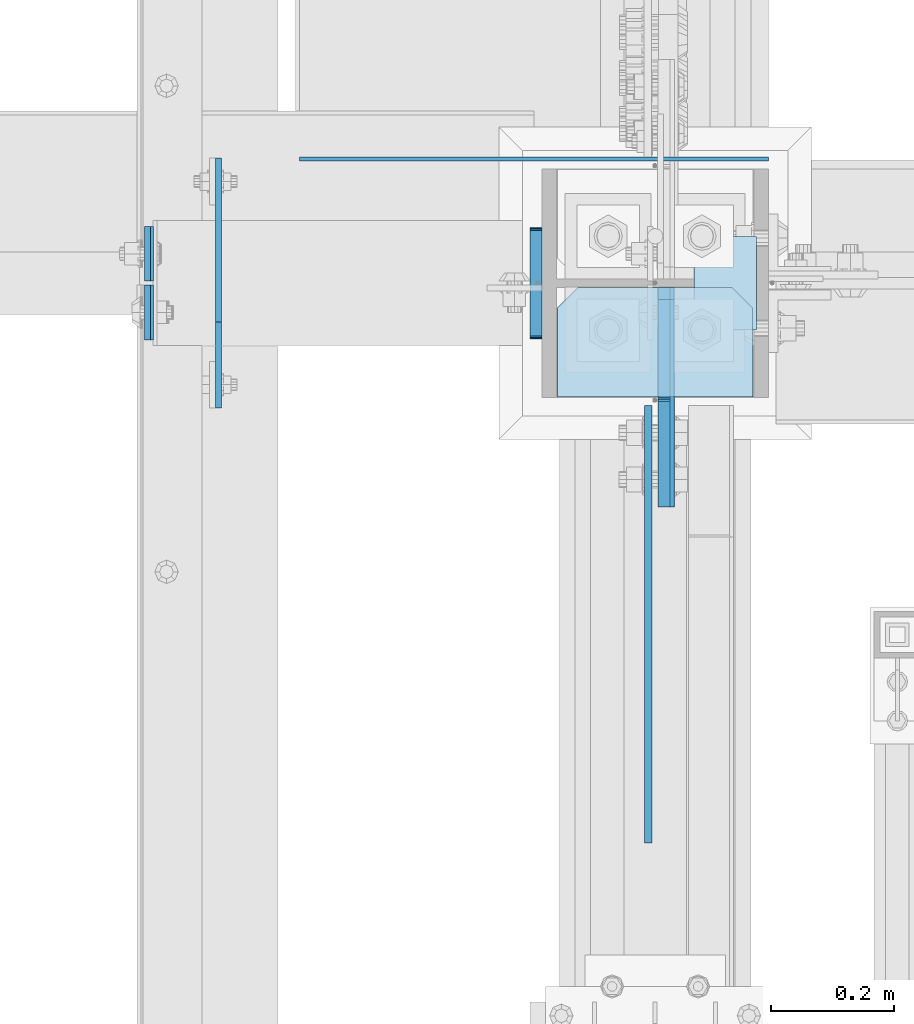
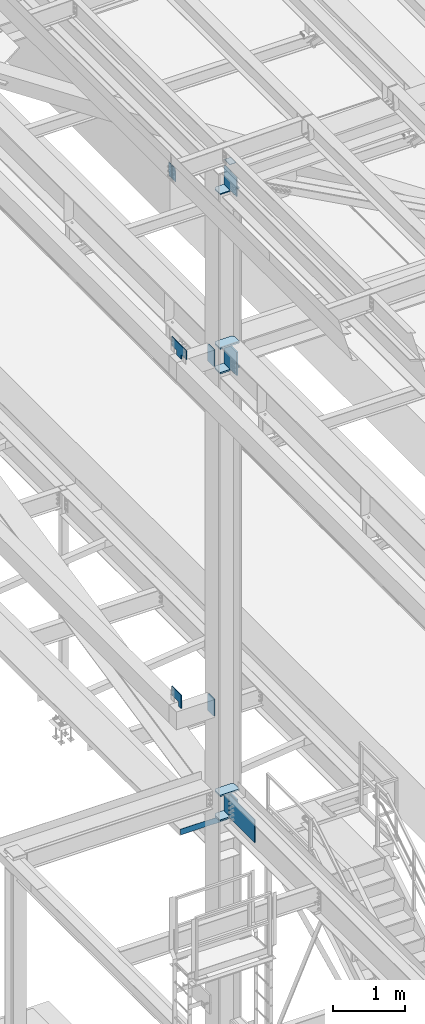
# One storey, part 3208 of 3843: 17 plates, 4 elements without a shape of their own.
"""IFC2X3 building model written with IfcOpenShell, lengths in millimetres."""

from ifc_helpers import new_model, si_unit, frame, origin_with_axes, place, context, subcontext, project, spatial, faceted_brep, material, type_object, element, aggregate, save


model = new_model("IFC2X3")

# Units and contexts
model_context = context("Model", 3, precision=1e-05, world=origin_with_axes())
body_context = subcontext(model_context, "Body", "Model", "MODEL_VIEW")
ifc_project = project(units=[si_unit("LENGTHUNIT", "METRE", prefix="MILLI"), si_unit("AREAUNIT", "SQUARE_METRE"), si_unit("VOLUMEUNIT", "CUBIC_METRE"), si_unit("MASSUNIT", "GRAM", prefix="KILO"), si_unit("TIMEUNIT", "SECOND"), si_unit("PLANEANGLEUNIT", "RADIAN"), si_unit("SOLIDANGLEUNIT", "STERADIAN"), si_unit("THERMODYNAMICTEMPERATUREUNIT", "DEGREE_CELSIUS"), si_unit("LUMINOUSINTENSITYUNIT", "LUMEN")], contexts=[model_context])

# Site, building, storey
site_placement = place(None, origin_with_axes())
site = spatial("IfcSite", under=ifc_project, at=site_placement, CompositionType="ELEMENT")
building_placement = place(site_placement, origin_with_axes())
building = spatial("IfcBuilding", under=site, at=building_placement, Name="Undefined", CompositionType="ELEMENT")
storey_placement = place(building_placement, origin_with_axes())
storey = spatial("IfcBuildingStorey", under=building, at=storey_placement, Name="Undefined", CompositionType="ELEMENT", Elevation=0.0)

# Assembly, plates
assembly_1_placement = place(storey_placement, origin_with_axes())
assembly_1 = element("IfcElementAssembly", 1, at=assembly_1_placement, inside=storey, Name="COLUMN", AssemblyPlace="NOTDEFINED", PredefinedType="RIGID_FRAME")
ifc_material = material(Name="STEEL/A572-50")
plate_type_1 = type_object("IfcPlateType", PredefinedType="NOTDEFINED")
plate_1_placement = place(assembly_1_placement, frame((36417.25, 33660.55625, 42005.249987793), z_axis=(1.0, 0.0, 0.0), x_axis=(0.0, 1.0, 0.0)))
plate_1 = element("IfcPlate", 2, at=plate_1_placement, type_object=plate_type_1, material=ifc_material, Name="PLATE", context=body_context, shape_type="Brep", body=[
    faceted_brep([(0.0, -12.6999999999971, 0.0), (0.0, -12.7000000020344, 317.500000001608), (0.0, 12.6999999977998, 317.500000001586), (0.0, 12.6999999999971, 0.0), (144.462501525879, -12.6999999999971, 317.5), (144.462501525879, 12.6999999999971, 317.5), (177.800003051758, -12.6999999999971, 284.162498474121), (177.800003051758, 12.6999999999971, 284.162498474121), (177.800003051758, -12.6999999999971, 33.3375015258789), (177.800003051758, 12.6999999999971, 33.3375015258789), (144.462501525879, -12.6999999999971, 0.0), (144.462501525879, 12.6999999999971, 0.0)], [[[0, 1, 2, 3]], [[1, 4, 5, 2]], [[4, 6, 7, 5]], [[6, 8, 9, 7]], [[8, 10, 11, 9]], [[10, 0, 3, 11]], [[5, 7, 9, 11, 3, 2]], [[10, 8, 6, 4, 1, 0]]]),
])
plate_2_placement = place(assembly_1_placement, frame((36417.25, 33660.55625, 42424.35), z_axis=(1.0, 0.0, 0.0), x_axis=(0.0, 1.0, 0.0)))
plate_2 = element("IfcPlate", 3, at=plate_2_placement, type_object=plate_type_1, material=ifc_material, Name="PLATE", context=body_context, shape_type="Brep", body=[
    faceted_brep([(0.0, -12.6999999999971, 0.0), (0.0, -12.7000000020344, 317.500000001608), (0.0, 12.6999999977998, 317.500000001586), (0.0, 12.6999999999971, 0.0), (144.462501525879, -12.6999999999971, 317.5), (144.462501525879, 12.6999999999971, 317.5), (177.800003051758, -12.6999999999971, 284.162498474121), (177.800003051758, 12.6999999999971, 284.162498474121), (177.800003051758, -12.6999999999971, 33.3375015258789), (177.800003051758, 12.6999999999971, 33.3375015258789), (144.462501525879, -12.6999999999971, 0.0), (144.462501525879, 12.6999999999971, 0.0)], [[[0, 1, 2, 3]], [[1, 4, 5, 2]], [[4, 6, 7, 5]], [[6, 8, 9, 7]], [[8, 10, 11, 9]], [[10, 0, 3, 11]], [[5, 7, 9, 11, 3, 2]], [[10, 8, 6, 4, 1, 0]]]),
])
plate_3_placement = place(assembly_1_placement, frame((36417.25, 33660.55625, 34372.55), z_axis=(1.0, 0.0, 0.0), x_axis=(0.0, 1.0, 0.0)))
plate_3 = element("IfcPlate", 4, at=plate_3_placement, type_object=plate_type_1, material=ifc_material, Name="PLATE", context=body_context, shape_type="Brep", body=[
    faceted_brep([(0.0, -12.6999999999971, 0.0), (0.0, -12.7000000020344, 317.500000001608), (0.0, 12.6999999977998, 317.500000001586), (0.0, 12.6999999999971, 0.0), (144.462501525879, -12.6999999999971, 317.5), (144.462501525879, 12.6999999999971, 317.5), (177.800003051758, -12.6999999999971, 284.162498474121), (177.800003051758, 12.6999999999971, 284.162498474121), (177.800003051758, -12.6999999999971, 33.3375015258789), (177.800003051758, 12.6999999999971, 33.3375015258789), (144.462501525879, -12.6999999999971, 0.0), (144.462501525879, 12.6999999999971, 0.0)], [[[0, 1, 2, 3]], [[1, 4, 5, 2]], [[4, 6, 7, 5]], [[6, 8, 9, 7]], [[8, 10, 11, 9]], [[10, 0, 3, 11]], [[5, 7, 9, 11, 3, 2]], [[10, 8, 6, 4, 1, 0]]]),
])
plate_4_placement = place(assembly_1_placement, frame((36417.25, 33660.55625, 34791.65), z_axis=(1.0, 0.0, 0.0), x_axis=(0.0, 1.0, 0.0)))
plate_4 = element("IfcPlate", 5, at=plate_4_placement, type_object=plate_type_1, material=ifc_material, Name="PLATE", context=body_context, shape_type="Brep", body=[
    faceted_brep([(0.0, -12.6999999999971, 0.0), (0.0, -12.7000000020344, 317.500000001608), (0.0, 12.6999999977998, 317.500000001586), (0.0, 12.6999999999971, 0.0), (144.462501525879, -12.6999999999971, 317.5), (144.462501525879, 12.6999999999971, 317.5), (177.800003051758, -12.6999999999971, 284.162498474121), (177.800003051758, 12.6999999999971, 284.162498474121), (177.800003051758, -12.6999999999971, 33.3375015258789), (177.800003051758, 12.6999999999971, 33.3375015258789), (144.462501525879, -12.6999999999971, 0.0), (144.462501525879, 12.6999999999971, 0.0)], [[[0, 1, 2, 3]], [[1, 4, 5, 2]], [[4, 6, 7, 5]], [[6, 8, 9, 7]], [[8, 10, 11, 9]], [[10, 0, 3, 11]], [[5, 7, 9, 11, 3, 2]], [[10, 8, 6, 4, 1, 0]]]),
])
plate_type_2 = type_object("IfcPlateType", PredefinedType="NOTDEFINED")
plate_5_placement = place(assembly_1_placement, frame((36595.0499999046, 33838.35625, 42411.65), z_axis=(0.0, -1.0, 0.0), x_axis=(0.0, 0.0, -1.0)))
plate_5 = element("IfcPlate", 6, at=plate_5_placement, type_object=plate_type_2, material=ifc_material, Name="PLATE", context=body_context, shape_type="Brep", body=[
    faceted_brep([(0.0, -12.6999999999971, 19.0499992370605), (0.0, -12.6999999999971, 356.393737792969), (0.0, 12.6999999999971, 356.393737792969), (0.0, 12.6999999999971, 19.0499992370605), (393.700012207031, -12.6999999999971, 356.393737792969), (393.700012207031, 12.6999999999971, 356.393737792969), (393.700012207031, -12.6999999999971, 19.0499992370605), (393.700012207031, 12.6999999999971, 19.0499992370605), (374.650012969971, -12.6999999999971, 0.0), (374.650012969971, 12.6999999999971, 0.0), (19.0500015258731, -12.6999999999971, -6.33008312433958e-10), (19.0500015258731, 12.6999999999971, 0.0)], [[[0, 1, 2, 3]], [[1, 4, 5, 2]], [[4, 6, 7, 5]], [[6, 8, 9, 7]], [[8, 10, 11, 9]], [[10, 0, 3, 11]], [[5, 7, 9, 11, 3, 2]], [[10, 8, 6, 4, 1, 0]]]),
])

assembly_2_placement = place(storey_placement, origin_with_axes())
assembly_2 = element("IfcElementAssembly", 7, at=assembly_2_placement, inside=storey, Name="BEAM", AssemblyPlace="NOTDEFINED", PredefinedType="RIGID_FRAME")
plate_type_3 = type_object("IfcPlateType", PredefinedType="NOTDEFINED")
plate_6_placement = place(assembly_2_placement, frame((35751.3030534739, 33842.325, 45674.0381290239), z_axis=(0.0, -1.0, 0.0), x_axis=(0.0211520550054438, 0.0, -0.999776270257025)))
plate_6 = element("IfcPlate", 8, at=plate_6_placement, type_object=plate_type_3, material=ifc_material, Name="PLATE", context=body_context, shape_type="Brep", body=[
    faceted_brep([(0.0, -4.76249999999709, 0.0), (0.0, -4.76249999999709, 88.9000015258789), (0.0, 4.76249999999709, 88.9000015258789), (0.0, 4.76249999999709, 0.0), (228.600006102781, -4.7625000004191, 88.9000015257589), (228.600006102781, 4.76249999954598, 88.9000015257443), (228.600006103079, -4.7625000004482, 7.27595761418343e-12), (228.600006103079, 4.76249999954598, -7.27595761418343e-12)], [[[0, 1, 2, 3]], [[1, 4, 5, 2]], [[4, 6, 7, 5]], [[6, 0, 3, 7]], [[5, 7, 3, 2]], [[6, 4, 1, 0]]]),
])
plate_7_placement = place(assembly_2_placement, frame((35751.3030534851, 33848.675, 45674.038129035), z_axis=(0.0, 1.0, 0.0), x_axis=(0.0211520550054438, 0.0, -0.999776270257025)))
plate_7 = element("IfcPlate", 9, at=plate_7_placement, type_object=plate_type_3, material=ifc_material, Name="PLATE", context=body_context, shape_type="Brep", body=[
    faceted_brep([(0.0, -4.76249999999709, 0.0), (0.0, -4.76249999999709, 88.9000015258789), (0.0, 4.76249999999709, 88.9000015258789), (0.0, 4.76249999999709, 0.0), (228.600006102781, -4.7625000004191, 88.9000015257589), (228.600006102781, 4.76249999954598, 88.9000015257443), (228.600006103079, -4.7625000004482, 7.27595761418343e-12), (228.600006103079, 4.76249999954598, -7.27595761418343e-12)], [[[0, 1, 2, 3]], [[1, 4, 5, 2]], [[4, 6, 7, 5]], [[6, 0, 3, 7]], [[5, 7, 3, 2]], [[6, 4, 1, 0]]]),
])
aggregate(assembly_2, [plate_6, plate_7])

# Plate
plate_type_4 = type_object("IfcPlateType", PredefinedType="NOTDEFINED")
plate_8_placement = place(assembly_1_placement, frame((36639.5, 33921.7000000002, 45420.756251), z_axis=(1.0, 0.0, 0.0), x_axis=(0.0, -1.0, 0.0)))
plate_8 = element("IfcPlate", 10, at=plate_8_placement, type_object=plate_type_4, material=ifc_material, Name="PLATE", context=body_context, shape_type="Brep", body=[
    faceted_brep([(0.0, -3.17499999999927, 0.0), (0.0, -3.17499999999927, 101.600000000006), (0.0, 3.17499999999927, 101.600000000006), (0.0, 3.17499999999927, 0.0), (152.399998474109, -3.17500000000291, 101.599998474121), (152.399998474109, 3.17500000000291, 101.599998474121), (152.399998474109, -3.17500000000291, 0.0), (152.399998474109, 3.17500000000291, 0.0)], [[[0, 1, 2, 3]], [[1, 4, 5, 2]], [[4, 6, 7, 5]], [[6, 0, 3, 7]], [[5, 7, 3, 2]], [[6, 4, 1, 0]]]),
])

# Assembly, plate
assembly_3_placement = place(storey_placement, origin_with_axes())
assembly_3 = element("IfcElementAssembly", 11, at=assembly_3_placement, inside=storey, Name="BEAM", AssemblyPlace="NOTDEFINED", PredefinedType="RIGID_FRAME")
plate_9_placement = place(assembly_3_placement, frame((35998.15, 34047.1125, 34036.0), z_axis=(0.0, 0.0, 1.0), x_axis=(1.0, 0.0, 0.0)))
plate_9 = element("IfcPlate", 12, at=plate_9_placement, type_object=plate_type_4, material=ifc_material, Name="PLATE", context=body_context, shape_type="Brep", body=[
    faceted_brep([(539.75, -3.17500000000291, 6.35000000000582), (539.75, 3.17500000000291, 6.35000000000582), (539.75, 3.17500000000291, 0.0), (539.75, -3.17500000000291, 0.0), (12.6999992370547, -3.17500000000291, 6.35000000000582), (12.6999992370547, 3.17500000000291, 6.35000000000582), (4.36557456851006e-11, -3.17499999998836, 19.0499992370969), (0.0, -3.17499999999927, 101.600000000006), (0.0, 3.17499999999927, 101.600000000006), (1.45519152283669e-11, 3.17499999998836, 19.0499992370824), (762.0, -3.17500000000291, 101.599999999999), (762.0, 3.17500000000291, 101.599999999999), (762.0, -3.17500000000291, 0.0), (762.0, 3.17500000000291, 0.0)], [[[0, 1, 2, 3]], [[4, 5, 1, 0]], [[6, 7, 8, 9]], [[7, 10, 11, 8]], [[10, 12, 13, 11]], [[13, 12, 3, 2]], [[9, 8, 11, 13, 2, 1, 5]], [[6, 9, 5, 4]], [[12, 10, 7, 6, 4, 0, 3]]]),
])
aggregate(assembly_3, [plate_9])

# Plate
plate_type_5 = type_object("IfcPlateType", PredefinedType="NOTDEFINED")
plate_10_placement = place(assembly_1_placement, frame((36417.25, 33660.55625, 45059.5999999876), z_axis=(1.0, 0.0, 0.0), x_axis=(0.0, 1.0, 0.0)))
plate_10 = element("IfcPlate", 13, at=plate_10_placement, type_object=plate_type_5, material=ifc_material, Name="PLATE", context=body_context, shape_type="Brep", body=[
    faceted_brep([(0.0, -9.52500000000146, 0.0), (0.0, -9.52500000000146, 317.5), (0.0, 9.52500000000146, 317.5), (0.0, 9.52500000000146, 0.0), (144.462501525879, -9.52500000000146, 317.5), (144.462501525879, 9.52500000000146, 317.5), (177.800003051758, -9.52500000000146, 284.162498474121), (177.800003051758, 9.52500000000146, 284.162498474121), (177.800003051758, -9.52500000000146, 33.3375015258789), (177.800003051758, 9.52500000000146, 33.3375015258789), (144.462501525879, -9.52500000000146, 0.0), (144.462501525879, 9.52500000000146, 0.0)], [[[0, 1, 2, 3]], [[1, 4, 5, 2]], [[4, 6, 7, 5]], [[6, 8, 9, 7]], [[8, 10, 11, 9]], [[10, 0, 3, 11]], [[5, 7, 9, 11, 3, 2]], [[10, 8, 6, 4, 1, 0]]]),
])

plate_type_6 = type_object("IfcPlateType", PredefinedType="NOTDEFINED")
plate_11_placement = place(assembly_1_placement, frame((35866.3875, 33782.0, 36404.55), z_axis=(0.0, 0.0, 1.0), x_axis=(0.0, 1.0, 0.0)))
plate_11 = element("IfcPlate", 14, at=plate_11_placement, type_object=plate_type_6, material=ifc_material, Name="PLATE", context=body_context, shape_type="Brep", body=[
    faceted_brep([(0.0, -4.76249999999709, 0.0), (0.0, -4.76249999999709, 228.599999999999), (0.0, 4.76249999999709, 228.599999999999), (0.0, 4.76249999999709, 0.0), (266.700012207031, -4.76249999999709, 228.600006103516), (266.700012207031, 4.76249999999709, 228.600006103516), (266.700012207031, -4.76249999999709, 76.1999969482422), (266.700012207031, 4.76249999999709, 76.1999969482422), (76.1999893188477, -4.76249999999709, 76.1999969482422), (76.1999893188477, 4.76249999999709, 76.1999969482422), (76.2000000012922, -4.76250000000073, 7.27595761418343e-11), (76.2000000012922, 4.76250000000073, 7.27595761418343e-11)], [[[0, 1, 2, 3]], [[1, 4, 5, 2]], [[4, 6, 7, 5]], [[6, 8, 9, 7]], [[8, 10, 11, 9]], [[10, 0, 3, 11]], [[5, 7, 9, 11, 3, 2]], [[10, 8, 6, 4, 1, 0]]]),
])

plate_12_placement = place(assembly_1_placement, frame((35866.3875, 33909.0, 42367.2), z_axis=(0.0, 0.0, 1.0), x_axis=(0.0, -1.0, 0.0)))
plate_12 = element("IfcPlate", 15, at=plate_12_placement, type_object=plate_type_6, material=ifc_material, Name="PLATE", context=body_context, shape_type="Brep", body=[
    faceted_brep([(0.0, -4.76249999999709, 0.0), (-3.49245965480804e-10, -4.76249999999709, 76.1999999999462), (-3.49245965480804e-10, 4.76249999999709, 76.1999999999462), (0.0, 4.76249999999709, 0.0), (-139.699996948242, -4.76249999999709, 76.1999969482422), (-139.699996948242, 4.76249999999709, 76.1999969482422), (-139.699996948242, -4.76249999999709, 228.600006103516), (-139.699996948242, 4.76249999999709, 228.600006103516), (266.700012207031, -4.76249999999709, 228.600006103516), (266.700012207031, 4.76249999999709, 228.600006103516), (266.700012207031, -4.76249999999709, 76.1999969482422), (266.700012207031, 4.76249999999709, 76.1999969482422), (126.999992370605, -4.76249999999709, 76.1999969482422), (126.999992370605, 4.76249999999709, 76.1999969482422), (126.999992370605, -4.76249999999709, 0.0), (126.999992370605, 4.76249999999709, 0.0)], [[[0, 1, 2, 3]], [[1, 4, 5, 2]], [[4, 6, 7, 5]], [[6, 8, 9, 7]], [[8, 10, 11, 9]], [[10, 12, 13, 11]], [[12, 14, 15, 13]], [[14, 0, 3, 15]], [[5, 7, 9, 11, 13, 15, 3, 2]], [[14, 12, 10, 8, 6, 4, 1, 0]]]),
])

plate_type_7 = type_object("IfcPlateType", PredefinedType="NOTDEFINED")
plate_13_placement = place(assembly_1_placement, frame((36382.325, 33755.0125, 42356.4551879883), z_axis=(0.0, 1.0, 0.0), x_axis=(0.0, 0.0, -1.0)))
plate_13 = element("IfcPlate", 16, at=plate_13_placement, type_object=plate_type_7, material=ifc_material, Name="PLATE", context=body_context, shape_type="Brep", body=[
    faceted_brep([(-8.22591685395256e-13, -9.52499999999854, 7.9375), (0.0, -9.52499999999418, 173.037499999991), (0.0, 9.52499999999418, 173.037499999991), (0.0, 9.52499999999418, 7.9375), (0.604206210693519, -9.52499999999418, 176.075049744395), (0.604206210693519, 9.52499999999418, 176.075049744395), (2.32483992433117, -9.52499999999418, 178.65016007566), (2.32483992433117, 9.52499999999418, 178.65016007566), (4.89995025560347, -9.52499999999418, 180.370793789305), (4.89995025560347, 9.52499999999418, 180.370793789305), (7.9375, -9.52499999999418, 180.974999999991), (7.9375, 9.52499999999418, 180.974999999991), (274.637499999997, -9.52499999999418, 180.974999999991), (274.637499999997, 9.52499999999418, 180.974999999991), (277.675049744394, -9.52499999999418, 180.370793789305), (277.675049744394, 9.52499999999418, 180.370793789305), (280.250160075666, -9.52499999999418, 178.65016007566), (280.250160075666, 9.52499999999418, 178.65016007566), (281.970793789304, -9.52499999999418, 176.075049744395), (281.970793789304, 9.52499999999418, 176.075049744395), (282.574999999997, -9.52499999999418, 173.037499999991), (282.574999999997, 9.52499999999418, 173.037499999991), (282.574999999997, -9.52499999999418, 7.9375), (282.574999999997, 9.52499999999418, 7.9375), (281.970793789304, -9.52499999999418, 4.8999502555962), (281.970793789304, 9.52499999999418, 4.8999502555962), (280.250160075666, -9.52499999999418, 2.32483992433117), (280.250160075666, 9.52499999999418, 2.32483992433117), (277.675049744394, -9.52499999999418, 0.604206210686243), (277.675049744394, 9.52499999999418, 0.604206210686243), (274.637499999997, -9.52499999999418, 0.0), (274.637499999997, 9.52499999999418, 0.0), (7.9375, -9.52499999999854, 0.0), (7.9375, 9.52499999999418, 0.0), (4.8999502555962, -9.52499999999418, 0.604206210693519), (4.8999502555962, 9.52499999999418, 0.604206210693519), (2.32483992433117, -9.52499999999418, 2.32483992433117), (2.32483992433117, 9.52499999999418, 2.32483992433117), (0.604206210686243, -9.52499999999418, 4.89995025560347), (0.604206210686243, 9.52499999999418, 4.89995025560347)], [[[0, 1, 2, 3]], [[1, 4, 5, 2]], [[4, 6, 7, 5]], [[6, 8, 9, 7]], [[8, 10, 11, 9]], [[10, 12, 13, 11]], [[12, 14, 15, 13]], [[14, 16, 17, 15]], [[16, 18, 19, 17]], [[18, 20, 21, 19]], [[20, 22, 23, 21]], [[22, 24, 25, 23]], [[24, 26, 27, 25]], [[26, 28, 29, 27]], [[28, 30, 31, 29]], [[30, 32, 33, 31]], [[32, 34, 35, 33]], [[34, 36, 37, 35]], [[36, 38, 39, 37]], [[38, 0, 3, 39]], [[5, 7, 9, 11, 13, 15, 17, 19, 21, 23, 25, 27, 29, 31, 33, 35, 37, 39, 3, 2]], [[38, 36, 34, 32, 30, 28, 26, 24, 22, 20, 18, 16, 14, 12, 10, 8, 6, 4, 1, 0]]]),
])

plate_14_placement = place(assembly_1_placement, frame((36382.325, 33755.0125, 36393.4375), z_axis=(0.0, 1.0, 0.0), x_axis=(0.0, 0.0, -1.0)))
plate_14 = element("IfcPlate", 17, at=plate_14_placement, type_object=plate_type_7, material=ifc_material, Name="PLATE", context=body_context, shape_type="Brep", body=[
    faceted_brep([(-8.22591685395256e-13, -9.52499999999854, 7.9375), (0.0, -9.52499999999418, 173.037499999991), (0.0, 9.52499999999418, 173.037499999991), (0.0, 9.52499999999418, 7.9375), (0.604206210693519, -9.52499999999418, 176.075049744395), (0.604206210693519, 9.52499999999418, 176.075049744395), (2.32483992433117, -9.52499999999418, 178.65016007566), (2.32483992433117, 9.52499999999418, 178.65016007566), (4.89995025560347, -9.52499999999418, 180.370793789305), (4.89995025560347, 9.52499999999418, 180.370793789305), (7.9375, -9.52499999999418, 180.974999999991), (7.9375, 9.52499999999418, 180.974999999991), (274.637499999997, -9.52499999999418, 180.974999999991), (274.637499999997, 9.52499999999418, 180.974999999991), (277.675049744394, -9.52499999999418, 180.370793789305), (277.675049744394, 9.52499999999418, 180.370793789305), (280.250160075666, -9.52499999999418, 178.65016007566), (280.250160075666, 9.52499999999418, 178.65016007566), (281.970793789304, -9.52499999999418, 176.075049744395), (281.970793789304, 9.52499999999418, 176.075049744395), (282.574999999997, -9.52499999999418, 173.037499999991), (282.574999999997, 9.52499999999418, 173.037499999991), (282.574999999997, -9.52499999999418, 7.9375), (282.574999999997, 9.52499999999418, 7.9375), (281.970793789304, -9.52499999999418, 4.8999502555962), (281.970793789304, 9.52499999999418, 4.8999502555962), (280.250160075666, -9.52499999999418, 2.32483992433117), (280.250160075666, 9.52499999999418, 2.32483992433117), (277.675049744394, -9.52499999999418, 0.604206210686243), (277.675049744394, 9.52499999999418, 0.604206210686243), (274.637499999997, -9.52499999999418, 0.0), (274.637499999997, 9.52499999999418, 0.0), (7.9375, -9.52499999999854, 0.0), (7.9375, 9.52499999999418, 0.0), (4.8999502555962, -9.52499999999418, 0.604206210693519), (4.8999502555962, 9.52499999999418, 0.604206210693519), (2.32483992433117, -9.52499999999418, 2.32483992433117), (2.32483992433117, 9.52499999999418, 2.32483992433117), (0.604206210686243, -9.52499999999418, 4.89995025560347), (0.604206210686243, 9.52499999999418, 4.89995025560347)], [[[0, 1, 2, 3]], [[1, 4, 5, 2]], [[4, 6, 7, 5]], [[6, 8, 9, 7]], [[8, 10, 11, 9]], [[10, 12, 13, 11]], [[12, 14, 15, 13]], [[14, 16, 17, 15]], [[16, 18, 19, 17]], [[18, 20, 21, 19]], [[20, 22, 23, 21]], [[22, 24, 25, 23]], [[24, 26, 27, 25]], [[26, 28, 29, 27]], [[28, 30, 31, 29]], [[30, 32, 33, 31]], [[32, 34, 35, 33]], [[34, 36, 37, 35]], [[36, 38, 39, 37]], [[38, 0, 3, 39]], [[5, 7, 9, 11, 13, 15, 17, 19, 21, 23, 25, 27, 29, 31, 33, 35, 37, 39, 3, 2]], [[38, 36, 34, 32, 30, 28, 26, 24, 22, 20, 18, 16, 14, 12, 10, 8, 6, 4, 1, 0]]]),
])

plate_type_8 = type_object("IfcPlateType", PredefinedType="NOTDEFINED")
plate_15_placement = place(assembly_1_placement, frame((36593.4625, 33838.35625, 34404.3), z_axis=(0.0, -0.707106781186682, 0.707106781186413), x_axis=(0.0, -0.707106781186548, -0.707106781186548)))
plate_15 = element("IfcPlate", 18, at=plate_15_placement, type_object=plate_type_8, material=ifc_material, Name="PLATE", context=body_context, shape_type="Brep", body=[
    faceted_brep([(0.0, -12.6999999999971, 0.0), (-251.44717138874, -12.6999999999971, 251.447171388725), (-251.44717138874, 12.6999999999971, 251.447171388725), (0.0, 12.6999999999971, 0.0), (-251.447171388732, -12.6999999999971, 278.387939751803), (-251.447171388732, 12.6999999999971, 278.387939751803), (-12.9091181739714, -12.6999999999971, 516.92599296655), (-12.9091181739714, 12.6999999999971, 516.92599296655), (265.478821577828, -12.6999999999971, 238.538053214754), (265.478821577828, 12.6999999999971, 238.538053214754), (26.9407683630998, -12.7000000000007, 3.63797880709171e-12), (26.9407683630998, 12.7000000000007, 3.63797880709171e-12)], [[[0, 1, 2, 3]], [[1, 4, 5, 2]], [[4, 6, 7, 5]], [[6, 8, 9, 7]], [[8, 10, 11, 9]], [[10, 0, 3, 11]], [[5, 7, 9, 11, 3, 2]], [[10, 8, 6, 4, 1, 0]]]),
])

# Assembly, plate
assembly_4_placement = place(storey_placement, origin_with_axes())
assembly_4 = element("IfcElementAssembly", 19, at=assembly_4_placement, inside=storey, Name="BEAM", AssemblyPlace="NOTDEFINED", PredefinedType="RIGID_FRAME")
plate_type_9 = type_object("IfcPlateType", PredefinedType="NOTDEFINED")
plate_16_placement = place(assembly_4_placement, frame((36564.8875, 33647.0625, 34385.249987793), z_axis=(0.0, 0.0, 1.0), x_axis=(0.0, -1.0, 0.0)))
plate_16 = element("IfcPlate", 20, at=plate_16_placement, type_object=plate_type_9, material=ifc_material, Name="PLATE", context=body_context, shape_type="Brep", body=[
    faceted_brep([(0.0, -6.3499999046162, 0.0), (0.0, -6.34999999999854, 393.700012207031), (0.0, 6.34999999999854, 393.700012207031), (7.27595761418343e-12, 6.3499999046162, 0.0), (711.199999999968, -6.35000000000582, 393.700012207031), (711.200000000012, 6.34999999999854, 393.700000000004), (711.199999999968, -6.35000000000582, 0.0), (711.199999999997, 6.34999999999854, 0.0)], [[[0, 1, 2, 3]], [[1, 4, 5, 2]], [[4, 6, 7, 5]], [[6, 0, 3, 7]], [[7, 3, 2, 5]], [[6, 4, 1, 0]]]),
])
aggregate(assembly_4, [plate_16])

# Plate
plate_type_10 = type_object("IfcPlateType", PredefinedType="NOTDEFINED")
plate_17_placement = place(assembly_1_placement, frame((36590.2875003815, 33838.35625, 45088.1750026613), z_axis=(0.0, -0.707106781186682, 0.707106781186413), x_axis=(0.0, -0.707106781186548, -0.707106781186548)))
plate_17 = element("IfcPlate", 21, at=plate_17_placement, type_object=plate_type_10, material=ifc_material, Name="PLATE", context=body_context, shape_type="Brep", body=[
    faceted_brep([(0.0, -9.52500000000146, 0.0), (-205.423360299239, -9.52500000000146, 205.423357237712), (-205.423360299239, 9.52500000000146, 205.423357237712), (0.0, 9.52500000000146, 0.0), (-205.423360299126, -9.52500000000146, 232.3641254002), (-205.423360299126, 9.52500000000146, 232.3641254002), (-92.608892539698, -9.52500000000146, 345.178591747157), (-92.608892539698, 9.52500000000146, 345.178591747157), (-89.0037379960995, -9.52500000000146, 342.769704533581), (-89.0037379960995, 9.52500000000146, 342.769704533581), (-84.751168274659, -9.52500000000146, 341.923815855786), (-84.751168274659, 9.52500000000146, 341.923815855786), (-80.4985985658241, -9.52500000000146, 342.769704596954), (-80.4985985658241, 9.52500000000146, 342.769704596954), (-76.8934440581252, -9.52500000000146, 345.178591864264), (-76.8934440581252, 9.52500000000146, 345.178591864264), (40.9724185538689, -9.52500000000146, 463.044456243078), (40.9724185538689, 9.52500000000146, 463.044456243078), (265.478821579974, -9.52500000000146, 238.538053217882), (265.478821579974, 9.52500000000146, 238.538053217882), (26.9407683632344, -9.52499999999964, 2.03726813197136e-10), (26.9407683632344, 9.52499999999964, 2.03726813197136e-10)], [[[0, 1, 2, 3]], [[1, 4, 5, 2]], [[4, 6, 7, 5]], [[6, 8, 9, 7]], [[8, 10, 11, 9]], [[10, 12, 13, 11]], [[12, 14, 15, 13]], [[14, 16, 17, 15]], [[16, 18, 19, 17]], [[18, 20, 21, 19]], [[20, 0, 3, 21]], [[5, 7, 9, 11, 13, 15, 17, 19, 21, 3, 2]], [[20, 18, 16, 14, 12, 10, 8, 6, 4, 1, 0]]]),
])

aggregate(assembly_1, [plate_8, plate_13, plate_14, plate_11, plate_1, plate_2, plate_5, plate_12, plate_10, plate_17, plate_3, plate_4, plate_15])

save(model, "model.ifc")
